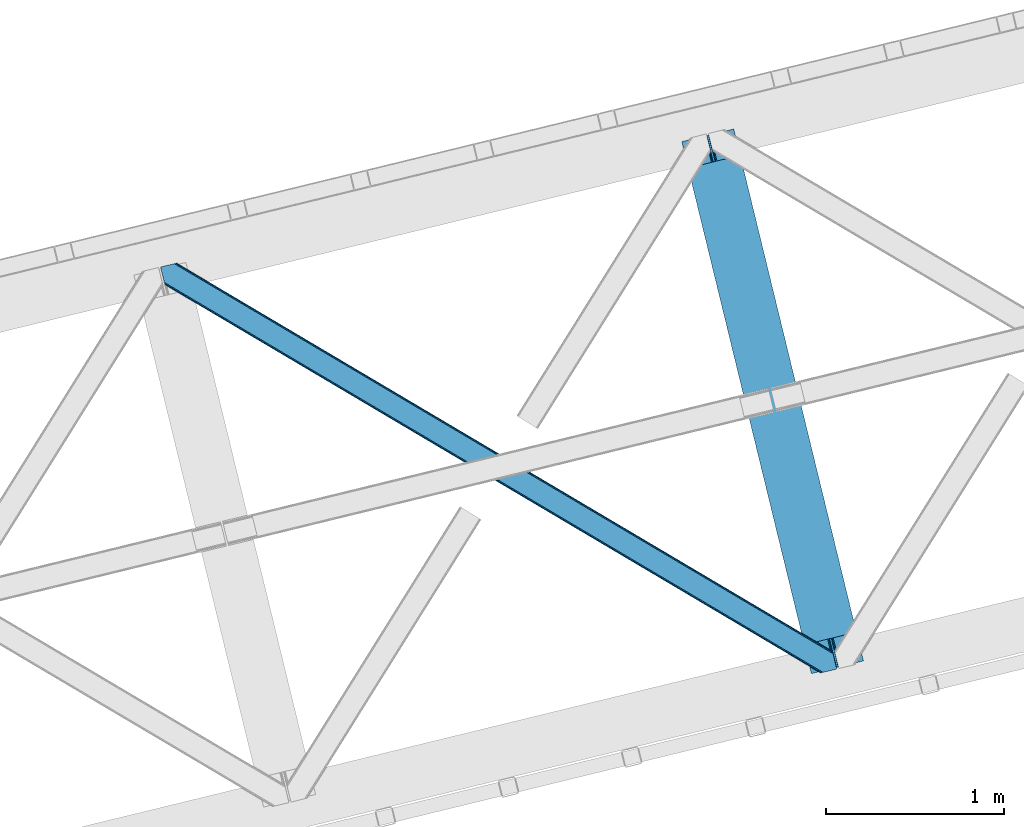
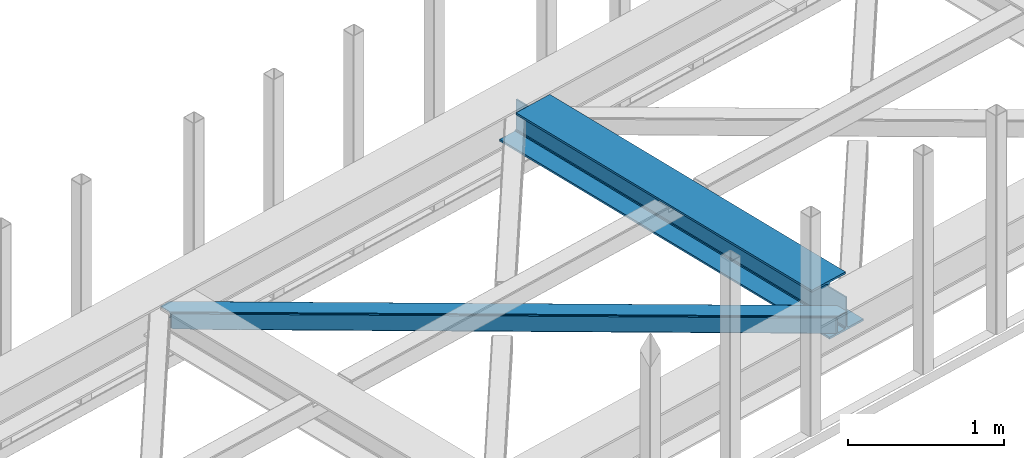
# One storey, part 47 of 66: 1 beam, 1 member.
"""IFC4 building model written with IfcOpenShell, lengths in millimetres."""

from ifc_helpers import new_model, entity, si_unit, converted_unit, derived_unit, direction, frame, origin, place, context, subcontext, project, spatial, triangles, polygons, material, type_object, element, save


model = new_model("IFC4")

# Units and contexts
model_context = context("Model", 3, precision=0.01, world=origin(), true_north=direction((6.12303176911189e-17, 1.0)))
plan_context = context("Plan", 3, precision=0.01, world=origin(), true_north=direction((6.12303176911189e-17, 1.0)))
body_context = subcontext(model_context, "Body", "Model", "MODEL_VIEW")
ifc_project = project(units=[si_unit("LENGTHUNIT", "METRE", prefix="MILLI"), si_unit("AREAUNIT", "SQUARE_METRE"), si_unit("VOLUMEUNIT", "CUBIC_METRE"), converted_unit("PLANEANGLEUNIT", "DEGREE", entity("IfcRatioMeasure", 0.0174532925199433), si_unit("PLANEANGLEUNIT", "RADIAN"), dimensions=[0, 0, 0, 0, 0, 0, 0]), si_unit("MASSUNIT", "GRAM", prefix="KILO"), derived_unit("MASSDENSITYUNIT", [(si_unit("MASSUNIT", "GRAM", prefix="KILO"), 1), (si_unit("LENGTHUNIT", "METRE"), -3)]), derived_unit("MOMENTOFINERTIAUNIT", [(si_unit("LENGTHUNIT", "METRE"), 4)]), si_unit("TIMEUNIT", "SECOND"), si_unit("FREQUENCYUNIT", "HERTZ"), si_unit("THERMODYNAMICTEMPERATUREUNIT", "DEGREE_CELSIUS"), derived_unit("THERMALTRANSMITTANCEUNIT", [(si_unit("MASSUNIT", "GRAM", prefix="KILO"), 1), (si_unit("THERMODYNAMICTEMPERATUREUNIT", "KELVIN"), -1), (si_unit("TIMEUNIT", "SECOND"), -3)]), derived_unit("VOLUMETRICFLOWRATEUNIT", [(si_unit("LENGTHUNIT", "METRE"), 3), (si_unit("TIMEUNIT", "SECOND"), -1)]), derived_unit("MASSFLOWRATEUNIT", [(si_unit("MASSUNIT", "GRAM", prefix="KILO"), 1), (si_unit("TIMEUNIT", "SECOND"), -1)]), derived_unit("ROTATIONALFREQUENCYUNIT", [(si_unit("TIMEUNIT", "SECOND"), -1)]), si_unit("ELECTRICCURRENTUNIT", "AMPERE"), si_unit("ELECTRICVOLTAGEUNIT", "VOLT"), si_unit("POWERUNIT", "WATT"), si_unit("FORCEUNIT", "NEWTON", prefix="KILO"), si_unit("ILLUMINANCEUNIT", "LUX"), si_unit("LUMINOUSFLUXUNIT", "LUMEN"), si_unit("LUMINOUSINTENSITYUNIT", "CANDELA"), derived_unit("USERDEFINED", [(si_unit("MASSUNIT", "GRAM", prefix="KILO"), -1), (si_unit("LENGTHUNIT", "METRE"), -2), (si_unit("TIMEUNIT", "SECOND"), 3), (si_unit("LUMINOUSFLUXUNIT", "LUMEN"), 1)]), derived_unit("LINEARVELOCITYUNIT", [(si_unit("LENGTHUNIT", "METRE"), 1), (si_unit("TIMEUNIT", "SECOND"), -1)]), si_unit("PRESSUREUNIT", "PASCAL"), derived_unit("USERDEFINED", [(si_unit("LENGTHUNIT", "METRE"), -2), (si_unit("MASSUNIT", "GRAM", prefix="KILO"), 1), (si_unit("TIMEUNIT", "SECOND"), -2)]), derived_unit("LINEARFORCEUNIT", [(si_unit("MASSUNIT", "GRAM", prefix="KILO"), 1), (si_unit("LENGTHUNIT", "METRE"), 1), (si_unit("TIMEUNIT", "SECOND"), -2), (si_unit("LENGTHUNIT", "METRE"), -1)]), derived_unit("PLANARFORCEUNIT", [(si_unit("MASSUNIT", "GRAM", prefix="KILO"), 1), (si_unit("LENGTHUNIT", "METRE"), 1), (si_unit("TIMEUNIT", "SECOND"), -2), (si_unit("LENGTHUNIT", "METRE"), -2)])], contexts=[model_context, plan_context])

# Site, building, storey
site_placement = place(None, origin())
site = spatial("IfcSite", under=ifc_project, at=site_placement, CompositionType="ELEMENT")
building_placement = place(site_placement, origin())
building = spatial("IfcBuilding", under=site, at=building_placement, CompositionType="ELEMENT")
storey_placement = place(building_placement, frame((0.0, 0.0, 19800.0)))
storey = spatial("IfcBuildingStorey", under=building, at=storey_placement, Name="06", CompositionType="ELEMENT", Elevation=19800.0)

# Beam
ifc_material = material(Name="Metal painted (White)")
beam_type = type_object("IfcBeamType", PredefinedType="BEAM")
beam_placement = place(storey_placement, frame((-14954.51, 14149.61, 3807.02)))
element("IfcBeam", 1, at=beam_placement, inside=storey, type_object=beam_type, material=ifc_material, ObjectType="Steel Beam", PredefinedType="BEAM", context=body_context, shape_type="Tessellation", body=[
    polygons([(1018.1664837833, 71.0478278971043, 15.5000000000008), (1018.16648378329, 71.0478278971043, 0.0), (291.465617442446, 3052.25531830422, 0.0), (291.465617442448, 3052.25531830422, 15.5000000000008), (894.779372399329, 40.9709140873291, 15.5000000000008), (168.078506058476, 3022.17840449444, 15.5000000000008), (888.087028625377, 39.3395844888265, 16.8701684147984), (161.386162284526, 3020.54707489594, 16.8701684147984), (882.413533524757, 37.9566100336519, 20.7720779386434), (155.712667183904, 3019.16410044077, 20.7720779386434), (878.622625296178, 37.0325360459162, 26.6116982174294), (151.921758955329, 3018.24002645303, 26.6116982174294), (877.291435352781, 36.7080444135051, 33.500000000001), (150.59056901193, 3017.91553482062, 33.500000000001), (140.875048430516, 3015.54727389071, 33.500000000001), (140.875048430512, 3015.54727389071, 259.000000000002), (150.590569011935, 3017.91553482062, 259.000000000002), (0.0, 2981.20749040711, 0.0), (0.0, 2981.20749040711, 15.4999999999965), (123.387111383964, 3011.28440421689, 15.5000000000008), (130.079455157924, 3012.91573381539, 16.8701684147941), (135.752950258549, 3014.29870827056, 20.7720779386434), (139.543858487119, 3015.2227822583, 26.6116982174294), (877.291435352788, 36.7080444135051, 259.000000000002), (867.575914771362, 34.3397834835992, 259.000000000002), (867.575914771367, 34.3397834835992, 33.500000000001), (866.24472482797, 34.0152918511859, 26.6116982174294), (862.453816599399, 33.0912178634524, 20.7720779386434), (856.780321498773, 31.70824340828, 16.8701684147941), (850.087977724817, 30.0769138097752, 15.5000000000008), (726.700866340853, 2.16573425859679e-12, 15.4999999999965), (726.700866340853, 2.16573425859679e-12, 0.0), (838.124523615921, 197.385937999185, 259.069791973884), (186.46972209998, 2870.72539801219, 259.000000000002), (186.693115201831, 2869.80895360721, 259.617303331124), (186.705504045461, 2869.75812937344, 266.500003008253), (837.979344808156, 197.981416001706, 266.500002998871), (837.979694928908, 197.979979696975, 260.000004007589), (828.499586345868, 194.645865944432, 259.006343171919), (828.276216326105, 195.562317481911, 259.617303331124), (828.263827482477, 195.613141715687, 266.500003008253), (176.989986719777, 2867.38985508742, 266.500002998871), (176.989636599025, 2867.39129139215, 260.000004007589), (176.844830940683, 2867.98534020594, 259.07612046749), (176.754201518552, 2868.35713708228, 259.000000000002), (839.310832678068, 198.30468544639, 273.388305639783), (843.101109266764, 199.231350618306, 279.227924098781), (848.7741802143, 200.616065081981, 283.129832400619), (855.466371895425, 202.248018612794, 284.500000377224), (978.853400583271, 232.325271667903, 284.500000138971), (978.85173077662, 232.332121736637, 299.999995328161), (687.386308679347, 161.283492472596, 299.999995890962), (687.387978485999, 161.276642403865, 284.500000701776), (810.775007173843, 191.353895458974, 284.500000463519), (817.467494069984, 192.984637925553, 283.129832461069), (823.141405718757, 194.365903570081, 279.227924137322), (826.93294050574, 195.287407219377, 273.388305663684), (175.658498849859, 2867.06658564273, 273.388305639783), (171.868222261169, 2866.13992047082, 279.227924098781), (166.195151313624, 2864.75520600714, 283.129832400619), (159.502959632495, 2863.12325247633, 284.500000377228), (36.1159309446555, 2833.04599942122, 284.500000138971), (36.117600751305, 2833.03914935249, 299.999995328161), (327.583022848578, 2904.08777861653, 299.999995890962), (327.58135304193, 2904.09462868526, 284.500000701776), (204.194324354077, 2874.01737563015, 284.500000463519), (197.501837457941, 2872.38663316357, 283.129832461069), (191.827925809181, 2871.00536751905, 279.227924137322), (188.036391022187, 2870.08386386975, 273.388305663684)], [[[1, 2, 3, 4]], [[5, 1, 4, 6]], [[7, 5, 6, 8]], [[9, 7, 8, 10]], [[11, 9, 10, 12]], [[13, 11, 12, 14]], [[15, 16, 17, 14, 12, 10, 8, 6, 4, 3, 18, 19, 20, 21, 22, 23]], [[13, 24, 25, 26, 27, 28, 29, 30, 31, 32, 2, 1, 5, 7, 9, 11]], [[2, 32, 18, 3]], [[32, 31, 19, 18]], [[31, 30, 20, 19]], [[27, 26, 15, 23]], [[28, 27, 23, 22]], [[29, 28, 22, 21]], [[30, 29, 21, 20]], [[33, 24, 13, 14, 17, 34, 35, 36, 37, 38]], [[25, 39, 40, 41, 42, 43, 44, 16, 15, 26]], [[39, 25, 24, 33]], [[45, 34, 17, 16]], [[41, 40, 38, 37, 46, 47, 48, 49, 50, 51, 52, 53, 54, 55, 56, 57]], [[42, 58, 59, 60, 61, 62, 63, 64, 65, 66, 67, 68, 69, 36, 35, 43]], [[46, 37, 36, 69]], [[47, 46, 69, 68]], [[48, 47, 68, 67]], [[49, 48, 67, 66]], [[50, 49, 66, 65]], [[51, 50, 65, 64]], [[52, 51, 64, 63]], [[53, 52, 63, 62]], [[54, 53, 62, 61]], [[55, 54, 61, 60]], [[56, 55, 60, 59]], [[57, 56, 59, 58]], [[41, 57, 58, 42]]], closed=False),
])

# Member
member_type = type_object("IfcMemberType", PredefinedType="BRACE")
member_placement = place(storey_placement, frame((-17875.18, 14152.66, 3823.0)))
element("IfcMember", 2, at=member_placement, inside=storey, type_object=member_type, ObjectType="Steel Horizontal Brace", PredefinedType="BRACE", context=body_context, shape_type="Tessellation", body=[
    triangles([(3167.12412414551, 476.930191040039, 17.5012573242202), (3764.84577941895, 123.065744018553, 122.499499511719), (3764.84577941895, 123.065744018553, 17.5012573242202), (2547.33172302246, 843.862445068358, 17.5012573242202), (1927.53932189941, 1210.79469909668, 17.5012573242202), (91.5002288818359, 2297.77602539063, 122.499499511719), (687.954519653322, 1944.65804443359, 17.5012573242202), (91.5002288818359, 2297.77602539063, 17.5012573242202), (1307.74692077637, 1577.726953125, 17.5012573242202), (3770.63961181641, 99.2985900878903, 140.00075683594), (3768.42230529785, 108.393383789062, 138.668280029298), (76.4767272949211, 2294.11345825195, 138.668280029298), (67.1679931640647, 2291.84499206543, 140.00075683594), (3766.54335021973, 116.104541015624, 134.87548828125), (84.3704315185569, 2296.03775939941, 134.87548828125), (3765.28761291504, 121.256552124023, 129.196765136719), (89.6480163574233, 2297.32489013672, 129.196765136719), (3722.23907775879, 5.93219604492151, 140.00075683594), (18.767459106446, 2198.47859802246, 140.00075683594), (3789.40707092285, 22.304452514647, 140.00075683594), (0.0, 2275.47157287597, 140.00075683594), (3697.90684204102, 0.0, 122.499499511719), (3699.75905456543, 0.452297973632085, 129.196765136719), (24.1194580078118, 2176.52063598633, 129.196765136719), (24.5612915039055, 2174.7114440918, 122.499499511719), (3705.03198852539, 1.73710327148365, 134.87548828125), (22.8637207031243, 2181.67264709473, 134.87548828125), (3712.92685546875, 3.66140441894458, 138.668280029298), (20.9847656250022, 2189.38264160156, 138.668280029298), (1862.08168945313, 1086.85342712402, 17.5012573242202), (2481.93571472168, 719.882803344726, 17.5012573242202), (3101.79555358887, 352.912179565428, 17.5012573242202), (3697.90684204102, 0.0, 17.5012573242202), (1242.22185058594, 1453.82405090332, 17.5012573242202), (622.367825317382, 1820.79467468262, 17.5012573242202), (24.5612915039055, 2174.7114440918, 17.5012573242202), (74.6373046875015, 2293.66581115723, 127.873590087893), (66.7436004638694, 2291.74151000977, 131.668707275392), (79.9148895263679, 2294.95177917481, 122.197192382813), (57.4348663330093, 2289.47304382324, 133.001184082033), (0.0, 2275.47157287597, 133.001184082033), (81.7671020507805, 2295.40407714844, 115.499926757813), (81.7671020507805, 2295.40407714844, 24.5008300781265), (79.9148895263679, 2294.95177917481, 17.8035644531265), (89.5573242187493, 2297.30279846191, 10.8156188964858), (89.4666320800789, 2297.28070678711, 10.4993591308594), (74.112918090821, 2293.53791198731, 12.4271484375022), (72.0339752197287, 2293.03096618652, 10.4993591308594), (1922.19081115723, 1205.8275604248, 24.5008300781265), (3767.16307983398, 113.558184814452, 115.499926757813), (2545.10627746582, 837.045419311524, 24.5008300781265), (3168.02523193359, 468.264440917968, 24.5008300781265), (3767.16307983398, 113.558184814452, 24.5008300781265), (1299.27185668945, 1574.60970153809, 24.5008300781265), (676.357553100588, 1943.39184265137, 24.5008300781265), (3767.60491333008, 111.750155639647, 122.197192382813), (3768.86065063477, 106.59814453125, 127.873590087893), (3770.73960571289, 98.886987304686, 131.668707275392), (3772.95691223145, 89.7921936035145, 133.001184082033), (3767.6932800293, 111.386224365233, 17.8686767578147), (3767.80141296387, 110.944390869139, 16.5199218750022), (3764.85508117676, 123.028536987304, 16.5199218750022), (3789.40707092285, 22.304452514647, 133.001184082033), (3731.97220458985, 8.30414428710901, 133.001184082033), (16.4501586914084, 2207.98499450684, 133.001184082033), (162.736578369142, 2253.90544738769, 10.4993591308594), (166.88748779297, 2236.87625427246, 10.4993591308594), (3722.65881958008, 6.03451538085938, 131.668707275392), (18.6674652099609, 2198.89020080566, 131.668707275392), (3714.76511535645, 4.11021423339844, 127.873590087893), (20.5464202880867, 2191.1790435791, 127.873590087893), (3709.49218139648, 2.82424621581958, 122.197192382813), (21.8021575927742, 2186.0270324707, 122.197192382813), (3707.63996887207, 2.37311096191297, 115.499926757813), (22.2439910888679, 2184.21784057617, 115.499926757813), (3114.18549499512, 353.713293457031, 24.5008300781265), (3707.63996887207, 2.37311096191297, 24.5008300781265), (2491.11538696289, 722.583801269531, 24.5008300781265), (1868.04992980957, 1091.45430908203, 24.5008300781265), (621.919015502932, 1829.19648742676, 24.5008300781265), (22.2439910888679, 2184.21784057617, 24.5008300781265), (1244.98447265625, 1460.32597961426, 24.5008300781265), (3709.49218139648, 2.82424621581958, 17.8035644531265), (3700.1299621582, 0.542990112304324, 10.8691040039084), (3700.58109741211, 0.652285766600471, 9.52034912109593), (3714.76511535645, 4.11021423339844, 12.1248413085959), (3719.39273986816, 5.23805236816406, 9.52034912109593), (21.7812286376975, 2186.11307373047, 17.817517089843), (21.7602996826172, 2186.20260314941, 17.5012573242202), (32.132922363282, 2171.84650268555, 10.8179443359368), (28.3459442138665, 2188.73965759277, 10.4993591308594), (27.0088165283196, 2187.35137023926, 12.1248413085959), (32.4968536376946, 2171.71046447754, 10.4993591308594), (203.965457153321, 2084.76925964355, 10.4993591308594), (208.116366577149, 2067.74006652832, 10.4993591308594), (164.09696044922, 2252.5485534668, 9.49942016601563), (168.582733154297, 2234.14618835449, 9.49942016601563), (168.164154052734, 2234.81824035644, 9.74591674804833), (163.767910766601, 2252.87644042969, 9.74126586914281), (167.732785034179, 2235.51005859375, 9.9993896484375), (163.414443969727, 2253.22641906738, 9.9993896484375), (167.304904174805, 2236.20303955078, 10.2528625488303), (163.060977172852, 2253.5775604248, 10.2598388671868), (209.161651611328, 2067.67262878418, 9.49942016601563), (209.130258178713, 2067.46682739258, 9.88311767578125), (204.677041625979, 2085.44363708496, 9.8528869628899), (208.802371215821, 2067.55635681152, 10.0831054687515), (204.682855224612, 2084.81228027344, 10.2063537597678), (208.444253540041, 2067.65053710938, 10.2993713378928), (204.323574829101, 2084.79018859863, 10.3528564453118), (204.675878906251, 2086.07615661621, 9.49942016601563), (3763.57376403809, 109.727023315429, 12.1248413085959), (3758.56593017578, 124.97144165039, 10.8714294433594), (3757.06369628906, 125.435366821288, 9.52034912109593), (3761.54249267578, 107.0643951416, 9.52034912109593), (3585.92297973633, 211.034793090819, 9.52034912109593), (3581.44418334961, 229.406927490234, 9.52034912109593), (3585.50556335449, 211.134786987304, 9.44360961914208), (3581.04420776367, 229.55343017578, 9.37384643554833), (3580.64539489746, 229.701095581055, 9.22734375000073), (3580.53261108399, 229.532501220703, 8.87387695312646), (3585.45556640625, 210.477850341797, 9.13897705078125), (3580.42564086914, 229.366232299804, 8.52041015625218), (3585.40324401856, 209.805798339843, 8.82736816406396), (3585.35324707031, 209.148861694335, 8.52041015625218), (3164.51265563965, 472.519995117187, 5.12526855468968), (3581.30116882324, 225.772265624999, 5.12526855468968), (3166.44625854492, 475.784912109375, 10.8039916992202), (687.27549133301, 1943.51276550293, 10.8039916992202), (685.343051147462, 1940.24784851074, 5.12526855468968), (165.152709960938, 2248.21625976563, 5.12526855468968), (682.450204467776, 1935.36210021973, 1.33247680664135), (167.031665039063, 2240.50626525879, 1.33247680664135), (679.039947509766, 1929.59966125488, 0.0), (169.248971557619, 2231.41030883789, 0.0), (3583.18128662109, 218.061108398437, 1.33247680664135), (3585.39743041992, 208.966314697265, 0.0), (3158.20955200195, 461.871807861327, 0.0), (3161.62097167969, 467.634246826172, 1.33247680664135), (2546.65385742188, 842.716003417969, 10.8039916992202), (1926.86145629883, 1209.64825744629, 10.8039916992202), (1307.06789245606, 1576.58051147461, 10.8039916992202), (2544.7202545166, 839.452249145508, 5.12526855468968), (1924.92785339356, 1206.38450317383, 5.12526855468968), (1305.13545227051, 1573.31559448242, 5.12526855468968), (2541.82857055664, 834.566500854491, 1.33247680664135), (1922.03500671387, 1201.49875488281, 1.33247680664135), (1302.24260559082, 1568.43100891113, 1.33247680664135), (2538.41715087891, 828.804061889648, 0.0), (1918.62474975586, 1195.73631591797, 0.0), (1298.83234863281, 1562.66740722656, 0.0), (3620.15809936524, 66.3668792724602, 0.0), (3110.71012573242, 367.971725463867, 0.0), (2490.85493774414, 734.942349243163, 0.0), (1870.99626159668, 1101.91297302246, 0.0), (631.282397460938, 1835.85422058105, 0.0), (1251.13642272949, 1468.88243408203, 0.0), (204.009640502929, 2088.81087341309, 0.0), (3167.34736633301, 467.117999267577, 17.8035644531265), (3165.41492614746, 463.853082275389, 12.1248413085959), (673.746084594728, 1938.98164672851, 12.1248413085959), (675.6796875, 1942.24540100098, 17.8035644531265), (670.854400634766, 1934.0958984375, 8.3320495605476), (169.397799682618, 2230.8022064209, 8.81806640624927), (171.566271972657, 2221.90391235351, 6.99957275390625), (3159.11065979004, 453.206057739257, 6.99957275390625), (3587.71473083496, 199.45991821289, 6.99957275390625), (3585.50556335449, 208.525643920897, 8.42274169921802), (3162.52207946777, 458.968496704101, 8.3320495605476), (667.442980957032, 1928.33345947266, 6.99957275390625), (2536.19170532227, 821.987036132812, 6.99957275390625), (2539.603125, 827.749475097657, 8.3320495605476), (1913.2774017334, 1190.76917724609, 6.99957275390625), (1916.68765869141, 1196.53161621094, 8.3320495605476), (1290.3572845459, 1559.55015563965, 6.99957275390625), (1293.76870422363, 1565.31259460449, 8.3320495605476), (2542.49480895996, 832.635223388672, 12.1248413085959), (1919.58050537109, 1201.41736450195, 12.1248413085959), (1296.66155090332, 1570.19834289551, 12.1248413085959), (2544.42841186524, 835.898977661132, 17.8035644531265), (1921.51294555664, 1204.68228149414, 17.8035644531265), (1298.59399108887, 1573.46325988769, 17.8035644531265), (201.692340087891, 2098.31726989746, 6.99957275390625), (203.86081237793, 2089.41897583008, 8.81806640624927), (206.225784301758, 2079.71491699219, 1.33247680664135), (208.105902099611, 2072.00492248535, 5.12526855468968), (2500.02995910645, 737.642184448241, 6.99957275390625), (3123.10006713867, 368.771676635741, 6.99957275390625), (1876.96450195313, 1106.51269226074, 6.99957275390625), (3617.8407989502, 75.8732757568359, 6.99957275390625), (630.832424926757, 1844.25487060547, 6.99957275390625), (1253.8990447998, 1475.38436279297, 6.99957275390625), (3119.68864746094, 363.009237670898, 8.3320495605476), (3620.55807495117, 65.0402160644517, 8.90410766601781), (3620.20228271484, 66.1843322753903, 8.52041015625218), (3116.79580078125, 358.124652099608, 12.1248413085959), (3621.04874267578, 64.3216552734375, 9.1087463378899), (3621.54754943848, 63.5926300048814, 9.31571044922021), (3622.03821716309, 62.8740692138672, 9.52034912109593), (3620.04996643066, 66.8075500488267, 8.42274169921802), (624.529321289065, 1833.60668334961, 12.1248413085959), (627.422167968751, 1838.49243164063, 8.3320495605476), (622.596881103516, 1830.34292907715, 17.8035644531265), (3114.8633605957, 354.85973510742, 17.8035644531265), (2491.79325256348, 723.730242919921, 17.8035644531265), (1868.72779541016, 1092.60075073242, 17.8035644531265), (1245.66233825684, 1461.47125854492, 17.8035644531265), (2493.72569274902, 726.993997192383, 12.1248413085959), (1870.6602355957, 1095.86450500488, 12.1248413085959), (1247.59477844238, 1464.73617553711, 12.1248413085959), (2496.61853942871, 731.879745483398, 8.3320495605476), (1873.55308227539, 1100.7502532959, 8.3320495605476), (1250.48762512207, 1469.62192382812, 8.3320495605476), (3102.47341918945, 354.05862121582, 10.8039916992202), (624.978131103515, 1825.2060333252, 5.12526855468968), (623.04569091797, 1821.94111633301, 10.8039916992202), (3626.51701354981, 44.5019348144524, 9.52034912109593), (3104.405859375, 357.323538208007, 5.12526855468968), (3624.25436096192, 49.5609283447266, 5.12526855468968), (3625.13105163574, 45.9669616699211, 8.52041015625218), (3625.82170715332, 45.2344482421868, 9.02037963867406), (3622.37540588379, 57.2709228515614, 1.33247680664135), (3107.29870605469, 362.208123779295, 1.33247680664135), (627.870977783205, 1830.09178161621, 1.33247680664135), (2487.4388671875, 729.178747558593, 1.33247680664135), (1867.58484191895, 1096.14937133789, 1.33247680664135), (1247.72616577148, 1463.11999511719, 1.33247680664135), (2484.54718322754, 724.292999267578, 5.12526855468968), (1864.69199523926, 1091.2647857666, 5.12526855468968), (1244.8333190918, 1458.23424682617, 5.12526855468968), (2482.61823120117, 721.030407714843, 10.8039916992202), (1862.75955505371, 1087.99986877441, 10.8039916992202), (1242.89971618652, 1454.97049255371, 10.8039916992202)], [[1, 2, 3], [2, 1, 4], [2, 5, 6], [5, 2, 4], [7, 8, 6], [9, 6, 5], [6, 9, 7], [10, 11, 12], [12, 13, 10], [11, 14, 15], [15, 12, 11], [14, 16, 17], [17, 15, 14], [16, 2, 6], [6, 17, 16], [18, 10, 19], [18, 20, 10], [13, 19, 10], [21, 19, 13], [22, 23, 24], [24, 25, 22], [23, 26, 27], [27, 24, 23], [26, 28, 29], [29, 27, 26], [28, 18, 19], [19, 29, 28], [30, 22, 25], [22, 31, 32], [30, 31, 22], [32, 33, 22], [34, 25, 35], [25, 34, 30], [36, 35, 25], [37, 38, 12], [15, 37, 12], [15, 17, 39], [37, 15, 39], [39, 17, 6], [38, 13, 12], [21, 40, 41], [21, 13, 40], [38, 40, 13], [39, 6, 42], [43, 8, 44], [6, 43, 42], [8, 45, 44], [6, 8, 43], [46, 44, 45], [46, 47, 44], [46, 48, 47], [49, 50, 42], [50, 51, 52], [49, 51, 50], [52, 53, 50], [54, 42, 55], [42, 54, 49], [43, 55, 42], [50, 56, 42], [39, 42, 56], [56, 57, 39], [37, 39, 57], [57, 58, 37], [38, 37, 58], [58, 59, 38], [40, 38, 59], [57, 14, 11], [59, 58, 10], [58, 57, 11], [60, 61, 62], [63, 59, 20], [10, 20, 59], [58, 11, 10], [60, 3, 53], [2, 50, 53], [53, 3, 2], [60, 62, 3], [2, 56, 50], [56, 14, 57], [14, 56, 16], [2, 16, 56], [59, 64, 65], [64, 59, 63], [65, 40, 59], [41, 40, 65], [66, 67, 46], [48, 46, 67], [64, 68, 65], [69, 65, 68], [68, 70, 69], [71, 69, 70], [70, 72, 71], [73, 71, 72], [72, 74, 73], [75, 73, 74], [76, 74, 77], [74, 76, 78], [74, 79, 75], [79, 74, 78], [80, 81, 75], [82, 75, 79], [75, 82, 80], [70, 68, 28], [26, 70, 28], [26, 23, 72], [70, 26, 72], [72, 23, 22], [68, 18, 28], [20, 64, 63], [20, 18, 64], [68, 64, 18], [72, 22, 74], [77, 33, 83], [22, 77, 74], [33, 84, 83], [22, 33, 77], [85, 83, 84], [86, 83, 85], [87, 86, 85], [73, 75, 25], [25, 24, 73], [27, 73, 24], [73, 27, 71], [25, 81, 36], [88, 89, 36], [36, 81, 88], [75, 81, 25], [69, 29, 19], [21, 65, 19], [41, 65, 21], [69, 71, 29], [29, 71, 27], [65, 69, 19], [90, 91, 92], [90, 93, 91], [92, 36, 90], [89, 36, 92], [94, 95, 93], [93, 91, 94], [96, 97, 98], [98, 99, 96], [99, 98, 100], [100, 101, 99], [101, 100, 102], [102, 103, 101], [103, 102, 67], [67, 66, 103], [104, 105, 106], [105, 107, 108], [108, 107, 109], [110, 109, 95], [95, 94, 110], [109, 110, 108], [108, 106, 105], [106, 111, 104], [62, 112, 113], [112, 62, 61], [112, 114, 113], [112, 115, 114], [114, 115, 116], [116, 117, 114], [118, 119, 117], [120, 119, 118], [121, 120, 122], [123, 121, 124], [124, 125, 123], [122, 124, 121], [118, 122, 120], [117, 116, 118], [1, 3, 113], [3, 62, 113], [120, 121, 126], [123, 126, 121], [123, 127, 126], [128, 113, 117], [117, 126, 128], [117, 119, 126], [120, 126, 119], [113, 114, 117], [45, 129, 66], [129, 130, 131], [131, 96, 129], [129, 99, 101], [99, 129, 96], [129, 103, 66], [103, 129, 101], [129, 45, 8], [8, 7, 129], [66, 46, 45], [130, 132, 133], [133, 131, 130], [132, 134, 135], [135, 133, 132], [136, 137, 138], [138, 139, 136], [127, 136, 139], [139, 126, 127], [113, 128, 1], [1, 128, 4], [140, 4, 128], [4, 140, 141], [141, 5, 4], [5, 141, 142], [142, 9, 5], [9, 142, 129], [129, 7, 9], [128, 126, 143], [143, 140, 128], [140, 143, 141], [144, 141, 143], [141, 144, 142], [145, 142, 144], [142, 145, 129], [130, 129, 145], [126, 139, 146], [146, 143, 126], [143, 146, 147], [147, 144, 143], [144, 147, 145], [148, 145, 147], [145, 148, 130], [132, 130, 148], [139, 138, 146], [149, 146, 138], [146, 149, 147], [150, 147, 149], [147, 150, 148], [151, 148, 150], [148, 151, 134], [134, 132, 148], [137, 152, 153], [138, 153, 154], [153, 138, 137], [149, 155, 150], [154, 149, 138], [149, 154, 155], [156, 134, 151], [150, 157, 151], [157, 150, 155], [157, 156, 151], [158, 134, 156], [135, 134, 158], [159, 160, 112], [112, 61, 159], [159, 60, 53], [161, 162, 44], [98, 163, 100], [98, 97, 163], [163, 102, 100], [163, 67, 102], [97, 164, 163], [161, 47, 67], [67, 163, 161], [47, 48, 67], [163, 164, 165], [166, 167, 168], [160, 118, 116], [116, 112, 160], [116, 115, 112], [169, 168, 125], [125, 160, 169], [124, 122, 160], [122, 118, 160], [160, 125, 124], [168, 169, 166], [165, 170, 163], [44, 47, 161], [162, 55, 43], [43, 44, 162], [53, 52, 159], [61, 60, 159], [166, 169, 171], [172, 171, 169], [171, 172, 173], [174, 173, 172], [173, 174, 175], [176, 175, 174], [175, 176, 163], [163, 170, 175], [169, 160, 177], [177, 172, 169], [172, 177, 178], [178, 174, 172], [174, 178, 179], [179, 176, 174], [176, 179, 163], [161, 163, 179], [160, 159, 177], [180, 177, 159], [177, 180, 178], [181, 178, 180], [178, 181, 179], [182, 179, 181], [179, 182, 161], [162, 161, 182], [159, 52, 180], [51, 180, 52], [180, 51, 49], [49, 181, 180], [181, 49, 182], [54, 182, 49], [182, 54, 162], [55, 162, 54], [97, 131, 133], [135, 97, 133], [165, 164, 135], [165, 135, 183], [131, 97, 96], [135, 164, 97], [183, 158, 184], [158, 185, 111], [158, 183, 135], [186, 111, 185], [158, 111, 184], [186, 104, 111], [187, 188, 166], [166, 171, 187], [171, 189, 187], [189, 171, 173], [188, 167, 166], [188, 190, 167], [170, 191, 175], [191, 170, 183], [165, 183, 170], [192, 175, 191], [173, 192, 189], [175, 192, 173], [193, 194, 195], [196, 197, 194], [196, 198, 197], [196, 199, 198], [194, 193, 196], [195, 200, 193], [86, 87, 199], [199, 196, 86], [193, 200, 190], [191, 183, 184], [201, 108, 110], [110, 94, 201], [94, 92, 201], [94, 91, 92], [202, 106, 108], [202, 111, 106], [202, 184, 111], [108, 201, 202], [203, 201, 92], [92, 89, 203], [203, 88, 81], [81, 80, 203], [89, 88, 203], [184, 202, 191], [190, 188, 193], [83, 86, 196], [196, 204, 83], [77, 83, 204], [204, 76, 77], [76, 204, 78], [205, 78, 204], [78, 205, 206], [206, 79, 78], [79, 206, 207], [207, 82, 79], [82, 207, 80], [203, 80, 207], [204, 196, 208], [208, 205, 204], [205, 208, 206], [209, 206, 208], [206, 209, 210], [210, 207, 206], [207, 210, 201], [201, 203, 207], [196, 193, 208], [211, 208, 193], [208, 211, 212], [212, 209, 208], [209, 212, 213], [213, 210, 209], [210, 213, 202], [202, 201, 210], [193, 188, 211], [187, 211, 188], [211, 187, 212], [189, 212, 187], [212, 189, 213], [192, 213, 189], [213, 192, 191], [191, 202, 213], [214, 84, 33], [35, 36, 90], [215, 105, 104], [216, 90, 95], [95, 215, 216], [95, 107, 215], [104, 186, 215], [84, 214, 217], [214, 218, 219], [219, 220, 214], [221, 217, 214], [214, 220, 221], [217, 85, 84], [222, 219, 218], [218, 223, 222], [152, 222, 223], [223, 153, 152], [156, 224, 185], [185, 158, 156], [224, 215, 186], [186, 185, 224], [90, 216, 35], [33, 32, 214], [153, 223, 154], [225, 154, 223], [154, 225, 155], [226, 155, 225], [155, 226, 157], [227, 157, 226], [157, 227, 224], [224, 156, 157], [223, 218, 228], [228, 225, 223], [225, 228, 229], [229, 226, 225], [226, 229, 227], [230, 227, 229], [227, 230, 224], [215, 224, 230], [218, 214, 228], [231, 228, 214], [228, 231, 229], [232, 229, 231], [229, 232, 230], [233, 230, 232], [230, 233, 215], [216, 215, 233], [214, 32, 31], [31, 231, 214], [231, 31, 232], [30, 232, 31], [232, 30, 34], [34, 233, 232], [233, 34, 35], [35, 216, 233], [137, 167, 190], [125, 127, 123], [137, 125, 167], [125, 136, 127], [125, 137, 136], [152, 137, 190], [195, 152, 190], [219, 195, 220], [195, 222, 152], [195, 219, 222], [220, 195, 194], [221, 194, 197], [221, 197, 198], [217, 198, 199], [87, 85, 199], [217, 199, 85]]),
])

save(model, "model.ifc")
